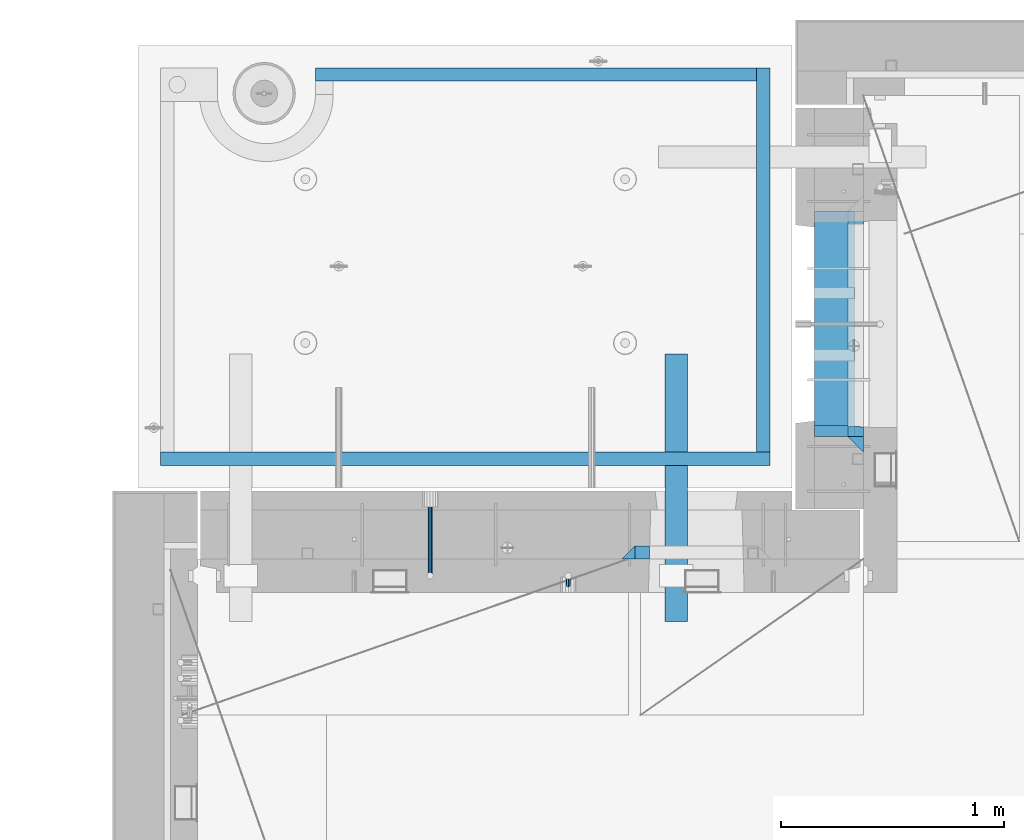
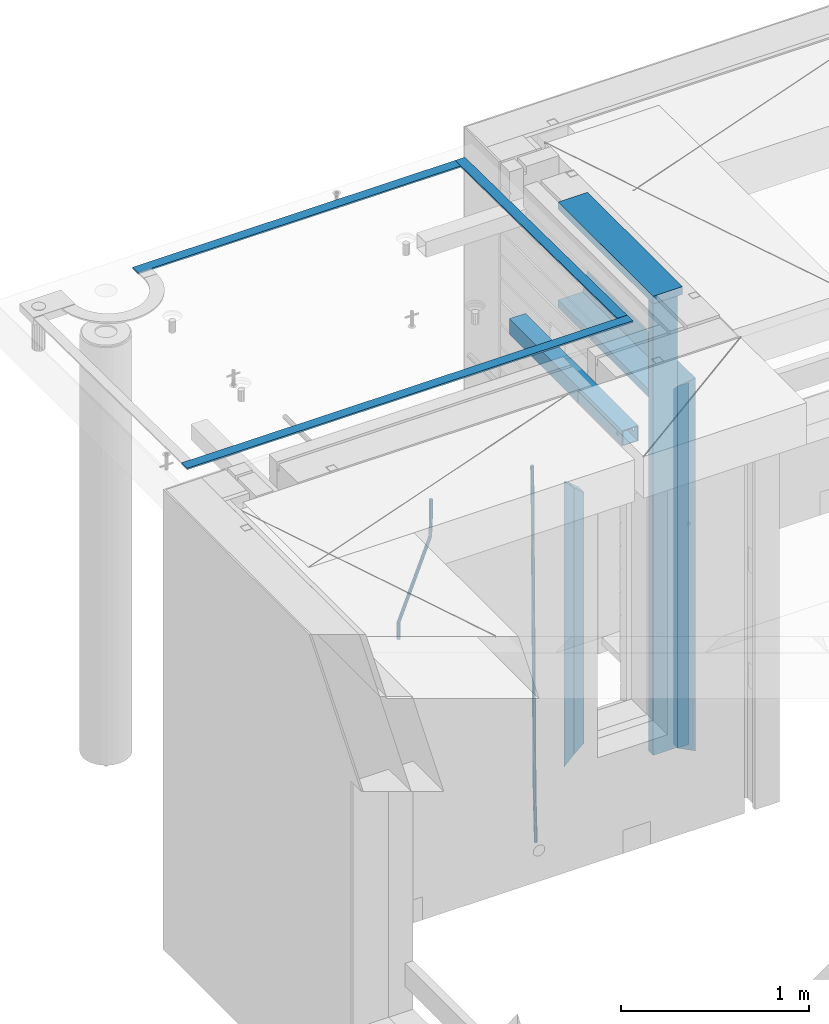
# One storey, part 110 of 334: 14 beams, 4 elements without a shape of their own.
"""IFC2X3 building model written with IfcOpenShell, lengths in millimetres."""

from ifc_helpers import new_model, si_unit, frame, origin_with_axes, place, context, subcontext, project, spatial, faceted_brep, material, type_object, element, aggregate, save


model = new_model("IFC2X3")

# Units and contexts
model_context = context("Model", 3, precision=1e-05, world=origin_with_axes())
body_context = subcontext(model_context, "Body", "Model", "MODEL_VIEW")
ifc_project = project(units=[si_unit("LENGTHUNIT", "METRE", prefix="MILLI"), si_unit("AREAUNIT", "SQUARE_METRE"), si_unit("VOLUMEUNIT", "CUBIC_METRE"), si_unit("MASSUNIT", "GRAM", prefix="KILO"), si_unit("TIMEUNIT", "SECOND"), si_unit("PLANEANGLEUNIT", "RADIAN"), si_unit("SOLIDANGLEUNIT", "STERADIAN"), si_unit("THERMODYNAMICTEMPERATUREUNIT", "DEGREE_CELSIUS"), si_unit("LUMINOUSINTENSITYUNIT", "LUMEN")], contexts=[model_context])

# Site, building, storey
site_placement = place(None, origin_with_axes())
site = spatial("IfcSite", under=ifc_project, at=site_placement, CompositionType="ELEMENT")
building_placement = place(site_placement, origin_with_axes())
building = spatial("IfcBuilding", under=site, at=building_placement, CompositionType="ELEMENT")
storey_placement = place(building_placement, origin_with_axes())
storey = spatial("IfcBuildingStorey", under=building, at=storey_placement, Name="3", CompositionType="ELEMENT", Elevation=0.0)

# Assembly, beams
assembly_1_placement = place(storey_placement, origin_with_axes())
assembly_1 = element("IfcElementAssembly", 1, at=assembly_1_placement, inside=storey, AssemblyPlace="NOTDEFINED", PredefinedType="REINFORCEMENT_UNIT")
ifc_material_1 = material(Name="CONCRETE/C25/30")
beam_type_1 = type_object("IfcBeamType", PredefinedType="NOTDEFINED")
beam_1_placement = place(assembly_1_placement, frame((10955.0, 22209.9998901814, 90140.0), z_axis=(0.0, 0.0, -1.0), x_axis=(0.0, -1.0, 0.0)))
beam_1 = element("IfcBeam", 2, at=beam_1_placement, type_object=beam_type_1, material=ifc_material_1, Name="SK", context=body_context, shape_type="Brep", body=[
    faceted_brep([(70.0000000000164, -35.0, 35.0), (70.0000000000164, 35.0, 35.0), (0.0, -35.0, -35.0), (1079.99961853027, -35.0, 35.0), (1079.99961853027, 35.0, 35.0), (1149.99961853027, -35.0, -35.0)], [[[0, 1, 2]], [[1, 0, 3, 4]], [[2, 1, 4, 5]], [[0, 2, 5, 3]], [[5, 4, 3]]]),
])
beam_2_placement = place(assembly_1_placement, frame((10955.0, 21095.0002716511, 90175.0), z_axis=(0.0, 1.0, 0.0), x_axis=(0.0, 0.0, -1.0)))
beam_2 = element("IfcBeam", 3, at=beam_2_placement, type_object=beam_type_1, material=ifc_material_1, Name="SK", context=body_context, shape_type="Brep", body=[
    faceted_brep([(2420.0, -35.0, 35.0), (2420.0, -35.0, -35.0), (2420.0, 35.0, 35.0), (70.0000000000164, -35.0, 35.0), (0.0, -35.0, -35.0), (70.0000000000164, 35.0, 35.0)], [[[0, 1, 2]], [[1, 0, 3, 4]], [[2, 1, 4, 5]], [[0, 2, 5, 3]], [[3, 5, 4]]]),
])
beam_type_2 = type_object("IfcBeamType", PredefinedType="NOTDEFINED")
beam_3_placement = place(assembly_1_placement, frame((10955.0, 21155.0002716511, 90105.0), z_axis=(0.0, 1.0, 0.0), x_axis=(0.0, 0.0, -1.0)))
beam_3 = element("IfcBeam", 4, at=beam_3_placement, type_object=beam_type_2, material=ifc_material_1, Name="SK", context=body_context, shape_type="Brep", body=[
    faceted_brep([(2350.0, -35.0, -25.0), (2350.0, 35.0, -25.0), (2350.0, 35.0, 20.6410256410309), (2350.0, -35.0, 18.8461538461561), (43.8461538461561, -35.0, 18.8461538461543), (0.0, -35.0, -25.0), (0.0, 35.0, -25.0), (45.6410256410309, 35.0, 20.6410256410254)], [[[0, 1, 2, 3]], [[0, 3, 4, 5]], [[1, 0, 5, 6]], [[2, 1, 6, 7]], [[3, 2, 7, 4]], [[7, 6, 5, 4]]]),
])
ifc_material_2 = material(Name="TIMBER")
beam_type_3 = type_object("IfcBeamType", Name="50X150", PredefinedType="NOTDEFINED")
beam_4_placement = place(assembly_1_placement, frame((10845.0, 22139.9998901814, 90080.0), z_axis=(0.0, 0.0, -1.0), x_axis=(0.0, -1.0, 0.0)))
beam_4 = element("IfcBeam", 5, at=beam_4_placement, type_object=beam_type_3, material=ifc_material_2, ObjectType="50X150", context=body_context, shape_type="Brep", body=[
    faceted_brep([(0.0, 75.0, -25.0), (1.81898940354586e-12, 75.0, 25.0), (1009.99961853027, 75.0, 25.0), (1009.99961853027, 75.0, -25.0), (1.81898940354586e-12, -75.0000000000009, 25.0), (1009.99961853027, -75.0, 25.0), (0.0, -75.0, -25.0), (1009.99961853027, -75.0, -25.0)], [[[0, 1, 2, 3]], [[1, 4, 5, 2]], [[4, 6, 7, 5]], [[6, 0, 3, 7]], [[5, 7, 3, 2]], [[6, 4, 1, 0]]]),
])
beam_5_placement = place(assembly_1_placement, frame((10845.0, 21155.0002716511, 90690.0), z_axis=(0.0, 1.0, 0.0), x_axis=(0.0, 0.0, -1.0)))
beam_5 = element("IfcBeam", 6, at=beam_5_placement, type_object=beam_type_3, material=ifc_material_2, ObjectType="50X150", context=body_context, shape_type="Brep", body=[
    faceted_brep([(0.0, 75.0, -25.0), (1.81898940354586e-12, 75.0, 25.0), (2930.0, 75.0, 25.0), (2930.0, 75.0, -25.0), (1.81898940354586e-12, -75.0000000000009, 25.0), (2930.0, -75.0, 25.0), (0.0, -75.0, -25.0), (2930.0, -75.0, -25.0)], [[[0, 1, 2, 3]], [[1, 4, 5, 2]], [[4, 6, 7, 5]], [[6, 0, 3, 7]], [[5, 7, 3, 2]], [[6, 4, 1, 0]]]),
])

assembly_2_placement = place(storey_placement, origin_with_axes())
assembly_2 = element("IfcElementAssembly", 7, at=assembly_2_placement, inside=storey, AssemblyPlace="NOTDEFINED", PredefinedType="REINFORCEMENT_UNIT")
ifc_material_3 = material()
beam_type_4 = type_object("IfcBeamType", Name="D20", PredefinedType="NOTDEFINED")
beam_6_placement = place(assembly_2_placement, frame((9665.0017200335, 20464.9951872276, 87990.0), z_axis=(-0.000205762999925498, 0.999642804629538, -0.0267249099901004), x_axis=(4.30000201928125e-08, 0.0267249099948059, 0.999642825806181)))
beam_6 = element("IfcBeam", 8, at=beam_6_placement, type_object=beam_type_4, material=ifc_material_3, Name="JM20", ObjectType="D20", context=body_context, shape_type="Brep", body=[
    faceted_brep([(0.0, -10.0, 0.0), (-4.19531716033816e-08, -7.07106781186667, -7.07106781187031), (60.4266690400545, -7.0710677960451, -7.07106780570757), (60.4266690441291, -9.99999998418934, 6.15546014159918e-09), (0.0, 0.0, -10.0), (60.426669036824, 1.58106558956206e-08, -9.99999999384454), (4.196772351861e-08, 7.07106781186303, -7.07106781186667), (60.4266690363438, 7.07106782768096, -7.07106780570757), (0.0, 10.0, 0.0), (60.4266690388904, 10.0000000158179, 6.15182216279209e-09), (4.196772351861e-08, 7.07106781185939, 7.07106781185939), (60.4266690429649, 7.07106782768096, 7.07106781802577), (0.0, 0.0, 10.0), (60.4266690461809, 1.58179318532348e-08, 10.0000000061555), (-4.19531716033816e-08, -7.07106781187031, 7.07106781185939), (60.4266690466611, -7.07106779605238, 7.07106781802213), (61.0378400410118, -7.07106779588503, -7.07106780564936), (60.991799419251, -9.99999998403655, 6.21366780251265e-09), (61.0569027789461, 1.5985278878361e-08, -9.99999999378269), (61.0378209396877, 7.07106782784831, -7.07106780564936), (60.9917724058905, 10.0000000159635, 6.21366780251265e-09), (60.9457317841297, 7.07106782781193, 7.0710678180767), (60.9266690461809, 1.59488990902901e-08, 10.0000000062028), (60.9457508854539, -7.07106779591413, 7.0710678180767), (61.6489592143771, -7.07106614513759, -7.06310863441468), (61.5568818710308, -9.9999984576425, 0.00735959856683621), (61.6870830769039, 1.71821739058942e-06, -9.99179257185824), (61.6489210170112, 7.07106947854481, -7.06310888312146), (61.556827851804, 10.0000015422847, 0.00735924683976918), (61.4647505084577, 7.07106922979438, 7.07782747982128), (61.4266266459163, 1.36643211590126e-06, 10.0065114172685), (61.464788705809, -7.07106639389531, 7.07782772852806), (176.543135720174, -7.07075579406956, -5.56673531796696), (176.451058376813, -9.99968810657447, 1.50373291501455), (176.581259582701, 0.000312069292704109, -8.49541925541052), (176.543097522794, 7.07137982961285, -5.56673556667374), (176.451004357587, 10.00031189336, 1.50373256329476), (176.35892701424, 7.07137958085514, 8.57420079627263), (176.320803151699, 0.000311717507429421, 11.5028847337162), (176.358965211621, -7.07075604281999, 8.57420104497578), (177.098753836006, -7.07075429323595, -5.55949898843028), (176.98362511232, -9.99968666800123, 1.510669025065), (177.146421932586, 0.000313595905026887, -8.48805862247536), (177.098706077581, 7.07138133041735, -5.55949936166144), (176.983557571715, 10.0003133318824, 1.51066849724157), (176.868428848029, 7.07138095712435, 8.58083651073321), (176.820760751449, 0.000313067976094317, 11.5093961447819), (176.868476606425, -7.07075466652896, 8.58083688396073), (177.654312950661, -7.07075204110879, -5.54863964998367), (177.516135294456, -9.99968450931192, 1.52107783331303), (177.711524267797, 0.000315886711177882, -8.47701274570863), (177.654255632195, 7.07138358250813, -5.54864021007961), (177.516054233929, 10.0003154905207, 1.5210770412159), (177.377876577739, 7.0713830223176, 8.59079452451624), (177.320665260588, 0.000315094497636892, 11.5191676202448), (177.377933896176, -7.07075260129932, 8.59079508461218), (299.436796249574, -7.07025836271714, -3.1681962331204), (299.298618593355, -9.99919083092027, 3.90152125031091), (299.494007566798, 0.000809565110102994, -6.09656932889993), (299.436738931283, 7.07187726089978, -3.16819679320906), (299.298537533061, 10.0008091689197, 3.90152045822106), (299.160359876842, 7.07187670072017, 10.9712379416487), (299.103148559603, 0.000808772889286047, 13.8996110374392), (299.160417195119, -7.07025892290039, 10.9712385017483), (299.98743051647, -7.07025613056248, -3.15743315966392), (299.971788958996, -9.99918809853989, 3.91467979818117), (299.993912075952, 0.000811591617093654, -6.08679785393178), (299.987423933868, 7.07187949325817, -3.1574327280432), (299.971753863239, 10.0008119014747, 3.91467990454839), (299.95611230444, 7.07187992653053, 10.9867922621015), (299.949630744944, 0.000812204350950196, 13.9161569563694), (299.956118887014, -7.07025569729012, 10.9867918304735), (300.538107039494, -7.07025785017686, -3.16575821840888), (300.644985195438, -9.99919020432935, 3.90450175465594), (300.493854948218, 0.000810030429420294, -6.09435592770024), (300.538151196495, 7.071877773491, -3.16575855385963), (300.645047642858, 10.0008097955724, 3.90450128024895), (300.751925798773, 7.07187744142357, 10.9747612533101), (300.796177890064, 0.000809560813650023, 13.9033589625978), (300.751881641787, -7.07025818224065, 10.9747615887682), (2293.36490490142, -7.07648090940347, -33.2930642912361), (2293.47178305736, -10.0054132635523, -26.2228043181785), (2293.32065281013, -0.00541302880083094, -36.2216620005347), (2293.36494905842, 7.06565471425711, -33.2930646266868), (2293.47184550477, 9.99458673634581, -26.2228047925819), (2293.57872366071, 7.06565438219332, -19.1525448195243), (2293.62297575199, -0.00541349841296324, -16.2239471102366), (2293.57867950371, -7.0764812414709, -19.1525444840736), (2294.0658245362, -7.07648309818615, -33.3036607065333), (2294.05312277409, -10.0054150789219, -26.2315929392535), (2294.10928714235, -0.00541549149056664, -36.2335844756526), (2294.15805078732, 7.06565223761572, -33.3050546393533), (2294.18355038921, 9.99458451388637, -26.2335642579346), (2294.17084862708, 7.06565253314329, -19.1614964906439), (2294.12738602093, -0.00541507354500936, -16.2315727215355), (2294.07862237596, -7.07648280265857, -19.1601025578348), (2294.76670261032, -7.08562269121467, -33.294332712383), (2294.63442802057, -10.0129954178956, -26.2238563411993), (2294.89787471293, -0.0156988342423574, -36.2230891548279), (2294.95110548967, 7.05531064255774, -33.2944998654275), (2294.89521307347, 9.98530428734011, -26.2240927312887), (2294.76293848372, 7.0579315606592, -19.1536163601049), (2294.63176638114, -0.0119922963167483, -16.2248599176673), (2294.57853560438, -7.08300177311321, -19.1534492070678), (2316.52657204497, -7.36937582653991, -33.0047303660212), (2316.39429745522, -10.2967485532172, -25.9342539948302), (2316.65774414754, -0.299451969567599, -35.9334868084661), (2316.7109749243, 6.7715575072325, -33.0048975190657), (2316.65508250811, 9.70155115201487, -25.9344903849269), (2316.52280791836, 6.7741784253376, -18.8640140137468), (2316.39163581574, -0.295745431634714, -15.9352575713092), (2316.33840503903, -7.36675490843481, -18.863846860706), (2317.16202064224, -7.37766220584308, -32.9962731735213), (2317.05438744847, -10.3053562613532, -25.9254688497131), (2317.23607125619, -0.306993473008333, -35.925789846493), (2317.23316144495, 6.76474808850253, -32.9979477328052), (2317.15499573652, 9.6950321815566, -25.9278370341635), (2317.04736254275, 6.7673381260538, -18.8570327103698), (2316.97331192881, -0.303330606784584, -15.9275160373909), (2316.97622174003, -7.37507216829545, -18.8553581510787), (2317.79752306276, -7.37578610372293, -32.9880110666527), (2317.71453320107, -10.3033876998124, -25.9168792378296), (2317.81444760226, -0.305295583297266, -35.918287695793), (2317.75539265381, 6.76628640723357, -32.9911928173897), (2317.65495180529, 9.69652304524061, -25.9213789128698), (2317.5719619436, 6.76892144914746, -18.8502470840467), (2317.55503740412, -0.301569071270933, -15.9199704549137), (2317.61409235255, -7.3731510618054, -18.847065333317), (2417.8183084176, -7.07752398473531, -31.6906369377139), (2417.73531855589, -10.0051255808248, -24.6195051088798), (2417.83523295709, -0.007033464313281, -34.6209135668432), (2417.77617800863, 7.06454852621755, -31.6938186884508), (2417.67573716014, 9.99478516423187, -24.6240047839383), (2417.59274729842, 7.06718356813872, -17.5528729551006), (2417.57582275895, -0.00330695228694822, -14.6225963259749), (2417.6348777074, -7.07488894281778, -17.5496912043673)], [[[0, 1, 2, 3]], [[1, 4, 5, 2]], [[4, 6, 7, 5]], [[6, 8, 9, 7]], [[8, 10, 11, 9]], [[10, 12, 13, 11]], [[12, 14, 15, 13]], [[14, 0, 3, 15]], [[14, 12, 10, 8, 6, 4, 1, 0]], [[3, 2, 16, 17]], [[2, 5, 18, 16]], [[5, 7, 19, 18]], [[7, 9, 20, 19]], [[9, 11, 21, 20]], [[11, 13, 22, 21]], [[13, 15, 23, 22]], [[15, 3, 17, 23]], [[17, 16, 24, 25]], [[16, 18, 26, 24]], [[18, 19, 27, 26]], [[19, 20, 28, 27]], [[20, 21, 29, 28]], [[21, 22, 30, 29]], [[22, 23, 31, 30]], [[23, 17, 25, 31]], [[25, 24, 32, 33]], [[24, 26, 34, 32]], [[26, 27, 35, 34]], [[27, 28, 36, 35]], [[28, 29, 37, 36]], [[29, 30, 38, 37]], [[30, 31, 39, 38]], [[31, 25, 33, 39]], [[33, 32, 40, 41]], [[32, 34, 42, 40]], [[34, 35, 43, 42]], [[35, 36, 44, 43]], [[36, 37, 45, 44]], [[37, 38, 46, 45]], [[38, 39, 47, 46]], [[39, 33, 41, 47]], [[41, 40, 48, 49]], [[40, 42, 50, 48]], [[42, 43, 51, 50]], [[43, 44, 52, 51]], [[44, 45, 53, 52]], [[45, 46, 54, 53]], [[46, 47, 55, 54]], [[47, 41, 49, 55]], [[49, 48, 56, 57]], [[48, 50, 58, 56]], [[50, 51, 59, 58]], [[51, 52, 60, 59]], [[52, 53, 61, 60]], [[53, 54, 62, 61]], [[54, 55, 63, 62]], [[55, 49, 57, 63]], [[57, 56, 64, 65]], [[56, 58, 66, 64]], [[58, 59, 67, 66]], [[59, 60, 68, 67]], [[60, 61, 69, 68]], [[61, 62, 70, 69]], [[62, 63, 71, 70]], [[63, 57, 65, 71]], [[65, 64, 72, 73]], [[64, 66, 74, 72]], [[66, 67, 75, 74]], [[67, 68, 76, 75]], [[68, 69, 77, 76]], [[69, 70, 78, 77]], [[70, 71, 79, 78]], [[71, 65, 73, 79]], [[73, 72, 80, 81]], [[72, 74, 82, 80]], [[74, 75, 83, 82]], [[75, 76, 84, 83]], [[76, 77, 85, 84]], [[77, 78, 86, 85]], [[78, 79, 87, 86]], [[79, 73, 81, 87]], [[81, 80, 88, 89]], [[80, 82, 90, 88]], [[82, 83, 91, 90]], [[83, 84, 92, 91]], [[84, 85, 93, 92]], [[85, 86, 94, 93]], [[86, 87, 95, 94]], [[87, 81, 89, 95]], [[89, 88, 96, 97]], [[88, 90, 98, 96]], [[90, 91, 99, 98]], [[91, 92, 100, 99]], [[92, 93, 101, 100]], [[93, 94, 102, 101]], [[94, 95, 103, 102]], [[95, 89, 97, 103]], [[97, 96, 104, 105]], [[96, 98, 106, 104]], [[98, 99, 107, 106]], [[99, 100, 108, 107]], [[100, 101, 109, 108]], [[101, 102, 110, 109]], [[102, 103, 111, 110]], [[103, 97, 105, 111]], [[105, 104, 112, 113]], [[104, 106, 114, 112]], [[106, 107, 115, 114]], [[107, 108, 116, 115]], [[108, 109, 117, 116]], [[109, 110, 118, 117]], [[110, 111, 119, 118]], [[111, 105, 113, 119]], [[113, 112, 120, 121]], [[112, 114, 122, 120]], [[114, 115, 123, 122]], [[115, 116, 124, 123]], [[116, 117, 125, 124]], [[117, 118, 126, 125]], [[118, 119, 127, 126]], [[119, 113, 121, 127]], [[121, 120, 128, 129]], [[120, 122, 130, 128]], [[122, 123, 131, 130]], [[123, 124, 132, 131]], [[124, 125, 133, 132]], [[125, 126, 134, 133]], [[126, 127, 135, 134]], [[127, 121, 129, 135]], [[130, 131, 132, 133, 134, 135, 129, 128]]]),
])
beam_7_placement = place(assembly_2_placement, frame((9044.99633337453, 20504.9951872346, 90407.5), z_axis=(0.000415599999849905, 0.999999913638203, 4.76000000899737e-07), x_axis=(0.0, 0.0, -1.0)))
beam_7 = element("IfcBeam", 9, at=beam_7_placement, type_object=beam_type_4, material=ifc_material_3, Name="JM20", ObjectType="D20", context=body_context, shape_type="Brep", body=[
    faceted_brep([(-0.00060564729210455, -9.99999998165731, 0.0), (-0.000428079845733009, -7.07106779890455, -7.07106781186667), (119.575515501536, -7.07830994756296, -7.07106481604933), (119.575337932896, -10.0072421307195, -3.43332612828817e-06), (0.0, 0.0, -10.0), (119.575943836026, -0.00724214867295814, -9.99999700418266), (0.00042843479604926, 7.07106779888636, -7.07106781186303), (119.57637202373, 7.06382565022977, -7.07106481604933), (0.00060564729210455, 9.99999998166459, 3.63797880709171e-12), (119.576549238118, 9.99275783300072, 2.99581552098971e-06), (0.000428079845733009, 7.07106779890819, 7.07106781186667), (119.576371669405, 7.06382565024978, 7.07107080768037), (0.0, 0.0, 10.0), (119.57594333493, -0.00724214864203532, 10.0000029958155), (-0.000428434810601175, -7.07106779888272, 7.07106781186667), (119.575515147211, -7.07830994754295, 7.07107080768037), (123.00654325854, -7.07836650239551, -6.96786008391246), (122.581588830741, -10.007295666459, 0.0904344953341933), (123.182419066041, -0.00729994480025198, -9.89151006310021), (123.006190977103, 7.06376911688858, -6.96788735351402), (122.581091016109, 9.99270432680532, 0.0903895128230943), (122.156136974867, 7.06377516229986, 7.14867767459873), (121.980261167351, -0.00729139528993983, 10.0723276537792), (122.156489256289, -7.07836045697513, 7.14870494419847), (237.077376207715, -7.07551629289992, -0.0988779924864502), (236.652422053201, -10.0044409119728, 6.95941204931296), (237.253252288647, -0.0044516184279928, -3.02253250974718), (237.077024472936, 7.06661932641327, -0.0989143382521434), (236.651924624995, 9.99555908263574, 6.95936064834314), (236.226970470365, 7.06663446442326, 14.0176506898479), (236.051094389448, -0.0044302100486675, 16.9413052071086), (236.227322205144, -7.07550115488812, 14.0176870356117), (256.715938387759, -7.07353516174771, 4.66794781703175), (253.858321224223, -10.0027051854922, 11.1357628166734), (257.898622435067, -0.00236892073007766, 1.98867362452802), (256.713573090979, 7.0686002544353, 4.66742272414376), (253.85497618909, 9.99729452004976, 11.1350202234971), (250.997359025234, 7.06812449537756, 17.6028352234607), (249.814674977912, -0.00304174564189452, 20.2821094159572), (250.999724322028, -7.07401092080545, 17.6033603163596), (1009.84102825288, -6.93521658215468, 337.477148757798), (1006.98341108896, -9.86438660663771, 343.944963757851), (1011.02371230032, 0.135949658781101, 334.7978745651), (1009.83866295629, 7.20691883402651, 337.476623664521), (1006.98006605446, 10.1356130998429, 343.944221163818), (1004.12244889054, 7.2064430753635, 350.412036163872), (1002.9397648431, 0.135276834424076, 353.091310356571), (1004.12481418712, -6.93569234081951, 350.412561257146), (1010.86335274603, -6.9350288225487, 337.928918327354), (1009.37086865908, -9.86394812736762, 344.999991477531), (1011.48104818776, 0.136033652863262, 334.999973251377), (1010.86211737194, 7.20710680115553, 337.928892551665), (1009.36912157628, 10.1360518725905, 344.9999550252), (1007.87663748935, 7.2071325677698, 352.071028175378), (1007.2589420476, 0.13607009235966, 354.999973251352), (1007.87787286344, -6.93500305593261, 352.071053951067), (1011.98104820926, -6.93502881915083, 337.92891832735), (1011.98104821818, -9.86394811943501, 344.999991477524), (1011.98104818776, 0.136033654382118, 334.999973251375), (1011.98104816627, 7.20710680455704, 337.928892551661), (1011.98104815738, 10.1360518805304, 344.999955025194), (1011.98104816629, 7.20713258024625, 352.071028175369), (1011.98104818778, 0.136070106711486, 354.999973251342), (1011.98104820927, -6.9350030434598, 352.071053951058), (1117.50000002154, -6.93502849844299, 337.928918327156), (1117.50000003044, -9.86394779872717, 344.999991477331), (1117.50000000004, 0.136033975091777, 334.999973251181), (1117.49999997855, 7.20710712526488, 337.928892551467), (1117.49999996964, 10.1360522012383, 344.999955025), (1117.49999997857, 7.20713290095409, 352.071028175174), (1117.50000000006, 0.136070427419327, 354.999973251148), (1117.50000002155, -6.93500272275196, 352.071053950864)], [[[0, 1, 2, 3]], [[1, 4, 5, 2]], [[4, 6, 7, 5]], [[6, 8, 9, 7]], [[8, 10, 11, 9]], [[10, 12, 13, 11]], [[12, 14, 15, 13]], [[14, 0, 3, 15]], [[14, 12, 10, 8, 6, 4, 1, 0]], [[3, 2, 16, 17]], [[2, 5, 18, 16]], [[5, 7, 19, 18]], [[7, 9, 20, 19]], [[9, 11, 21, 20]], [[11, 13, 22, 21]], [[13, 15, 23, 22]], [[15, 3, 17, 23]], [[17, 16, 24, 25]], [[16, 18, 26, 24]], [[18, 19, 27, 26]], [[19, 20, 28, 27]], [[20, 21, 29, 28]], [[21, 22, 30, 29]], [[22, 23, 31, 30]], [[23, 17, 25, 31]], [[25, 24, 32, 33]], [[24, 26, 34, 32]], [[26, 27, 35, 34]], [[27, 28, 36, 35]], [[28, 29, 37, 36]], [[29, 30, 38, 37]], [[30, 31, 39, 38]], [[31, 25, 33, 39]], [[33, 32, 40, 41]], [[32, 34, 42, 40]], [[34, 35, 43, 42]], [[35, 36, 44, 43]], [[36, 37, 45, 44]], [[37, 38, 46, 45]], [[38, 39, 47, 46]], [[39, 33, 41, 47]], [[41, 40, 48, 49]], [[40, 42, 50, 48]], [[42, 43, 51, 50]], [[43, 44, 52, 51]], [[44, 45, 53, 52]], [[45, 46, 54, 53]], [[46, 47, 55, 54]], [[47, 41, 49, 55]], [[49, 48, 56, 57]], [[48, 50, 58, 56]], [[50, 51, 59, 58]], [[51, 52, 60, 59]], [[52, 53, 61, 60]], [[53, 54, 62, 61]], [[54, 55, 63, 62]], [[55, 49, 57, 63]], [[57, 56, 64, 65]], [[56, 58, 66, 64]], [[58, 59, 67, 66]], [[59, 60, 68, 67]], [[60, 61, 69, 68]], [[61, 62, 70, 69]], [[62, 63, 71, 70]], [[63, 57, 65, 71]], [[66, 67, 68, 69, 70, 71, 65, 64]]]),
])

# Assemblies, beams
assembly_3_placement = place(storey_placement, origin_with_axes())
assembly_3 = element("IfcElementAssembly", 10, at=assembly_3_placement, inside=storey, AssemblyPlace="NOTDEFINED", PredefinedType="REINFORCEMENT_UNIT")
assembly_4_placement = place(assembly_3_placement, origin_with_axes())
assembly_4 = element("IfcElementAssembly", 11, at=assembly_4_placement, AssemblyPlace="NOTDEFINED", PredefinedType="NOTDEFINED")
ifc_material_4 = material(Name="Undefined/350")
beam_type_5 = type_object("IfcBeamType", Name="100X100X5", PredefinedType="NOTDEFINED")
beam_8_placement = place(assembly_4_placement, frame((10150.0001432011, 21500.0034426031, 90555.0), z_axis=(0.0, 0.0, 1.0), x_axis=(-2.2242999997242e-05, -0.999999999752625, 0.0)))
beam_8 = element("IfcBeam", 12, at=beam_8_placement, type_object=beam_type_5, material=ifc_material_4, ObjectType="100X100X5", context=body_context, shape_type="Brep", body=[
    faceted_brep([(1143.75108023171, 44.9999999999982, -10.8253175473074), (1143.75107855316, 50.0255964196231, -10.8253175473074), (1139.17576100585, 50.0255948914664, -6.25), (1139.1757626844, 44.9999999999982, -6.25), (1150.00108023171, 44.9999999999982, -12.5), (1150.00107855316, 50.0255985071226, -12.5), (1156.2510802317, 44.9999999999982, -10.8253175473074), (1156.25107855315, 50.0256005946221, -10.8253175473074), (1160.82639777901, 44.9999999999982, -6.25), (1160.82639610046, 50.0256021227788, -6.25), (1162.50108023171, 44.9999999999982, 0.0), (1162.50107855316, 50.0256026821226, 0.0), (1160.82639777901, 44.9999999999982, 6.25), (1160.82639610046, 50.0256021227788, 6.25), (1156.2510802317, 44.9999999999982, 10.8253175473074), (1156.25107855315, 50.0256005946221, 10.8253175473074), (1150.00108023171, 44.9999999999982, 12.5), (1150.00107855316, 50.0255985071226, 12.5), (1143.75108023171, 44.9999999999982, 10.8253175473074), (1143.75107855316, 50.0255964196231, 10.8253175473074), (1139.1757626844, 44.9999999999982, 6.25), (1139.17576100585, 50.0255948914664, 6.25), (1137.5010802317, 44.9999999999982, 0.0), (1137.50107855316, 50.0255943321226, 0.0), (1143.75111195316, -49.9744035792783, -10.8253175473074), (1143.75111029171, -44.9999999999991, -10.8253175473074), (1139.1757927444, -44.9999999999991, -6.25), (1139.17579440585, -49.9744051074349, -6.25), (1150.00111195316, -49.9744014917787, -12.5), (1150.00111029171, -44.9999999999991, -12.5), (1156.25111195316, -49.9743994042774, -10.8253175473074), (1156.25111029171, -44.9999999999991, -10.8253175473074), (1160.82642950046, -49.9743978761207, -6.25), (1160.82642783901, -44.9999999999991, -6.25), (1162.50111195316, -49.9743973167779, 0.0), (1162.50111029171, -44.9999999999991, 0.0), (1160.82642950046, -49.9743978761207, 6.25), (1160.82642783901, -44.9999999999991, 6.25), (1156.25111195316, -49.9743994042774, 10.8253175473074), (1156.25111029171, -44.9999999999991, 10.8253175473074), (1150.00111195316, -49.9744014917787, 12.5), (1150.00111029171, -44.9999999999991, 12.5), (1143.75111195316, -49.9744035792783, 10.8253175473074), (1143.75111029171, -44.9999999999991, 10.8253175473074), (1139.17579440585, -49.9744051074349, 6.25), (1139.1757927444, -44.9999999999991, 6.25), (1137.50111195316, -49.9744056667778, 0.0), (1137.50111029171, -44.9999999999991, 0.0), (1.81898940354586e-12, -50.0000000000009, -50.0), (1.81898940354586e-12, 49.9999999999991, -50.0), (1200.00449189278, 49.9999999999982, -50.0), (1200.00449189278, -50.0000000000009, -50.0), (1.81898940354586e-12, 49.9999999999991, 50.0), (1.81898940354586e-12, -50.0000000000009, 50.0), (1200.00449189278, -50.0000000000009, 50.0), (1200.00449189278, 49.9999999999982, 50.0), (0.0, 44.9999999999991, 45.0), (1.81898940354586e-12, -45.0000000000009, 45.0), (1.81898940354586e-12, -45.0000000000009, -45.0), (0.0, 44.9999999999991, -45.0), (1200.00449189278, 44.9999999999982, -45.0), (1200.00449189278, 44.9999999999982, 45.0), (1200.00449189278, -45.0000000000009, 45.0), (1200.00449189278, -45.0000000000009, -45.0)], [[[0, 1, 2, 3]], [[4, 5, 1, 0]], [[6, 7, 5, 4]], [[8, 9, 7, 6]], [[10, 11, 9, 8]], [[12, 13, 11, 10]], [[14, 15, 13, 12]], [[16, 17, 15, 14]], [[18, 19, 17, 16]], [[20, 21, 19, 18]], [[22, 23, 21, 20]], [[3, 2, 23, 22]], [[24, 25, 26, 27]], [[28, 29, 25, 24]], [[30, 31, 29, 28]], [[32, 33, 31, 30]], [[34, 35, 33, 32]], [[36, 37, 35, 34]], [[38, 39, 37, 36]], [[40, 41, 39, 38]], [[42, 43, 41, 40]], [[44, 45, 43, 42]], [[46, 47, 45, 44]], [[27, 26, 47, 46]], [[48, 49, 50, 51]], [[52, 53, 54, 55]], [[49, 52, 55, 50], [15, 17, 19, 21, 23, 2, 1, 5, 7, 9, 11, 13]], [[48, 53, 52, 49], [56, 57, 58, 59]], [[56, 59, 60, 61], [6, 4, 0, 3, 22, 20, 18, 16, 14, 12, 10, 8]], [[57, 56, 61, 62]], [[58, 57, 62, 63], [39, 41, 43, 45, 47, 26, 25, 29, 31, 33, 35, 37]], [[59, 58, 63, 60]], [[54, 51, 50, 55], [62, 61, 60, 63]], [[53, 48, 51, 54], [30, 28, 24, 27, 46, 44, 42, 40, 38, 36, 34, 32]]]),
])
aggregate(assembly_4, [beam_8])
ifc_material_5 = material(Name="CONCRETE/Concrete_Undefined")
beam_type_6 = type_object("IfcBeamType", PredefinedType="NOTDEFINED")
beam_9_placement = place(assembly_3_placement, frame((8529.99466999203, 22755.2837502302, 90704.830444231), z_axis=(-8.94119999996021e-05, 2.00000067707701e-09, 0.999999996002747), x_axis=(0.999999995749149, -2.25209999937896e-05, 8.94119999812374e-05)))
beam_9 = element("IfcBeam", 13, at=beam_9_placement, type_object=beam_type_6, material=ifc_material_5, context=body_context, shape_type="Brep", body=[
    faceted_brep([(2.5465851649642e-11, 29.9999999999982, -4.99999999998545), (-2.91038304567337e-11, 29.9999999999982, 5.0), (1980.00575712919, 30.0, 5.0), (1980.00575712919, 30.0, -5.0), (-2.5465851649642e-11, -30.0000000000018, 5.0), (1980.00575712919, -30.0, 5.0), (2.72848410531878e-11, -30.0000000000018, -4.99999999998545), (1980.00575712919, -30.0, -5.00000000001455)], [[[0, 1, 2, 3]], [[1, 4, 5, 2]], [[4, 6, 7, 5]], [[6, 0, 3, 7]], [[5, 7, 3, 2]], [[6, 4, 1, 0]]]),
])
beam_10_placement = place(assembly_3_placement, frame((10540.0586106742, 21059.9845873458, 90725.6637899649), z_axis=(-4.06999999693443e-07, 0.0121707750045615, 0.999925933374879), x_axis=(-3.34759999933477e-05, 0.999925932814682, -0.0121707749977451)))
beam_10 = element("IfcBeam", 14, at=beam_10_placement, type_object=beam_type_6, material=ifc_material_5, context=body_context, shape_type="Brep", body=[
    faceted_brep([(2.5465851649642e-11, 29.9999999999982, -4.99999999998545), (-2.91038304567337e-11, 29.9999999999982, 5.0), (1725.44357525616, 30.0000000000036, 5.00000000001455), (1725.4435752563, 30.0, -4.9999999999709), (-2.5465851649642e-11, -30.0000000000018, 5.0), (1725.44357525616, -29.9999999999964, 5.0000000000291), (2.72848410531878e-11, -30.0000000000018, -4.99999999998545), (1725.4435752563, -30.0, -4.99999999998545)], [[[0, 1, 2, 3]], [[1, 4, 5, 2]], [[4, 6, 7, 5]], [[6, 0, 3, 7]], [[5, 7, 3, 2]], [[6, 4, 1, 0]]]),
])
beam_11_placement = place(assembly_3_placement, frame((7834.99819277187, 21029.998155674, 90725.2788443216), z_axis=(-0.000140627000015522, 4.00000135459113e-09, 0.999999990112023), x_axis=(0.999999989763253, -2.64109999939869e-05, 0.000140626999967189)))
beam_11 = element("IfcBeam", 15, at=beam_11_placement, type_object=beam_type_6, material=ifc_material_5, context=body_context, shape_type="Brep", body=[
    faceted_brep([(2.5465851649642e-11, 29.9999999999982, -4.99999999998545), (-2.91038304567337e-11, 29.9999999999982, 5.0), (2735.00002544224, 30.0, 5.0), (2735.00002544224, 30.0, -5.0), (-2.5465851649642e-11, -30.0000000000018, 5.0), (2735.00002544224, -29.9999999999964, 5.0), (2.72848410531878e-11, -30.0000000000018, -4.99999999998545), (2735.00002544224, -29.9999999999964, -5.0)], [[[0, 1, 2, 3]], [[1, 4, 5, 2]], [[4, 6, 7, 5]], [[6, 0, 3, 7]], [[5, 7, 3, 2]], [[6, 4, 1, 0]]]),
])
aggregate(assembly_3, [beam_9, assembly_4, beam_10, beam_11])

# Beam
beam_type_7 = type_object("IfcBeamType", PredefinedType="NOTDEFINED")
beam_12_placement = place(assembly_2_placement, frame((9934.99871015549, 20609.9951872276, 90175.0), z_axis=(1.0, 0.0, 0.0), x_axis=(0.0, 0.0, -1.0)))
beam_12 = element("IfcBeam", 16, at=beam_12_placement, type_object=beam_type_7, material=ifc_material_1, Name="SK", context=body_context, shape_type="Brep", body=[
    faceted_brep([(60.0000000000073, 30.0, 30.0), (0.0, -30.0, -30.0), (60.0000000000073, -30.0, 30.0), (1795.00000000001, 30.0, 30.0), (1855.0, -30.0, -30.0), (1795.00000000001, -30.0, 30.0)], [[[0, 1, 2]], [[3, 4, 1, 0]], [[4, 5, 2, 1]], [[5, 3, 0, 2]], [[5, 4, 3]]]),
])

beam_type_8 = type_object("IfcBeamType", PredefinedType="NOTDEFINED")
beam_13_placement = place(assembly_2_placement, frame((9999.99871015549, 20609.9951872276, 90115.0), z_axis=(1.0, 0.0, 0.0), x_axis=(0.0, 0.0, -1.0)))
beam_13 = element("IfcBeam", 17, at=beam_13_placement, type_object=beam_type_8, material=ifc_material_1, Name="SK", context=body_context, shape_type="Brep", body=[
    faceted_brep([(0.0, -30.0, -35.0), (54.9034748914273, -30.0, 29.0540540540533), (56.2934362811066, 30.0, 30.6756756756768), (0.0, 30.0, -35.0), (1678.70656371891, 30.0, 30.6756756756768), (1735.0, 30.0, -35.0), (1735.0, -30.0, -35.0), (1680.09652510857, -30.0, 29.0540540540533)], [[[0, 1, 2, 3]], [[3, 2, 4, 5]], [[5, 6, 0, 3]], [[1, 0, 6, 7]], [[2, 1, 7, 4]], [[6, 5, 4, 7]]]),
])

aggregate(assembly_2, [beam_6, beam_7, beam_12, beam_13])

beam_type_9 = type_object("IfcBeamType", PredefinedType="NOTDEFINED")
beam_14_placement = place(assembly_1_placement, frame((10860.0, 21129.9999618525, 90715.0), z_axis=(0.0, 0.0, 1.0), x_axis=(0.0, 1.0, 0.0)))
beam_14 = element("IfcBeam", 18, at=beam_14_placement, type_object=beam_type_9, material=ifc_material_2, context=body_context, shape_type="Brep", body=[
    faceted_brep([(0.0, 90.0, -25.0), (0.0, 90.0, 25.0), (1009.99983857082, 90.0, 25.0), (1009.99983857082, 90.0, -25.0), (0.0, -90.0, 25.0), (1009.99983857082, -90.0, 25.0), (0.0, -90.0, -25.0), (1009.99983857082, -90.0, -25.0)], [[[0, 1, 2, 3]], [[1, 4, 5, 2]], [[4, 6, 7, 5]], [[6, 0, 3, 7]], [[5, 7, 3, 2]], [[6, 4, 1, 0]]]),
])

aggregate(assembly_1, [beam_1, beam_2, beam_3, beam_4, beam_5, beam_14])

save(model, "model.ifc")
